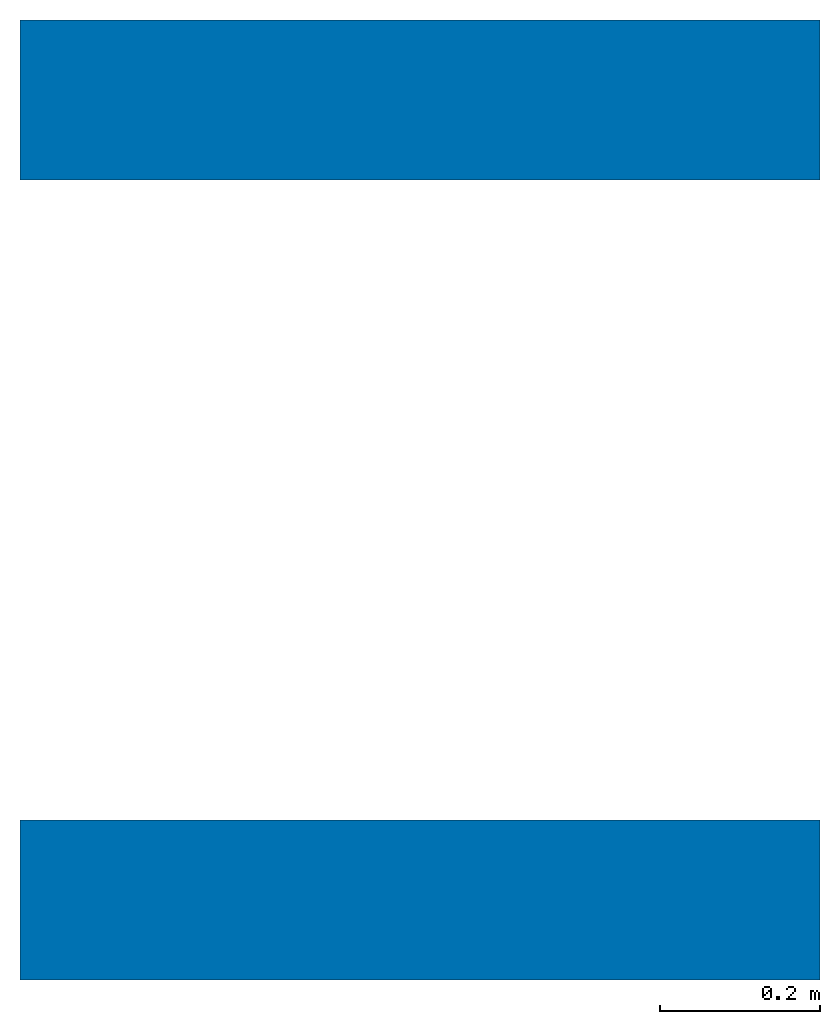
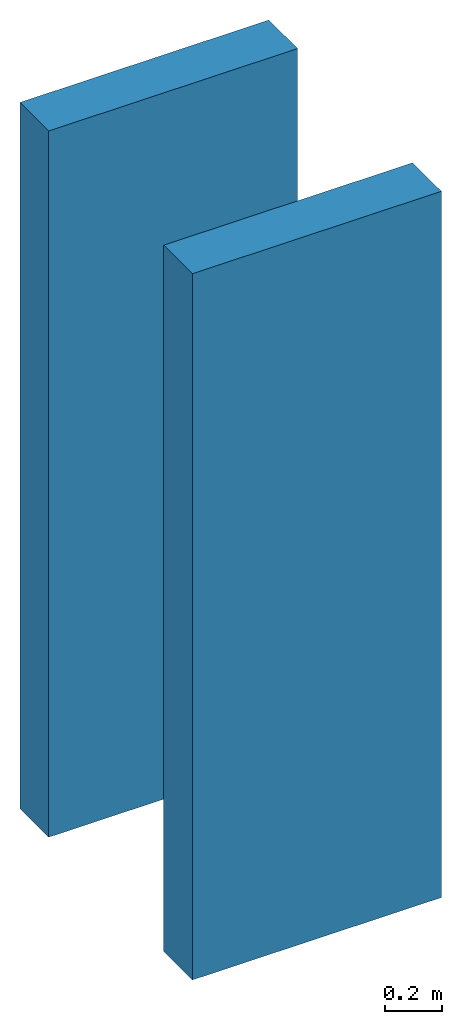
# One storey: 2 walls.
"""IFC4 building model written with IfcOpenShell, lengths in metres."""

from ifc_helpers import new_model, si_unit, frame, origin_with_axes, place, context, subcontext, project, spatial, polygons, source, transform, mapped, element, save


model = new_model("IFC4")

# Units and contexts
model_context = context("Model", 3, precision=1e-05, world=origin_with_axes())
plan_context = context("Plan", 2, precision=1e-05, world=origin_with_axes())
body_context = subcontext(model_context, "Body", "Model", "MODEL_VIEW")
ifc_project = project(units=[si_unit("LENGTHUNIT", "METRE"), si_unit("AREAUNIT", "SQUARE_METRE"), si_unit("VOLUMEUNIT", "CUBIC_METRE")], contexts=[model_context, plan_context])

# Site, building, storey
site_placement = place(None, origin_with_axes())
site = spatial("IfcSite", under=ifc_project, at=site_placement)
building_placement = place(site_placement, origin_with_axes())
building = spatial("IfcBuilding", under=site, at=building_placement, Name="Building")
storey_placement = place(building_placement, origin_with_axes())
storey = spatial("IfcBuildingStorey", under=building, at=storey_placement, Name="Ground Floor")

# Walls
shared_shape_1 = source(origin_with_axes(), body_context, "Body", "Tessellation", [
    polygons([(0.0, 0.0, 0.0), (1.0, 0.0, 0.0), (0.0, 0.0, 3.0), (1.0, 0.0, 3.0), (0.0, -0.200000002980232, 0.0), (1.0, -0.200000002980232, 0.0), (0.0, -0.200000002980232, 3.0), (1.0, -0.200000002980232, 3.0)], [[[3, 4, 2, 1]], [[7, 5, 6, 8]], [[1, 2, 6, 5]], [[3, 1, 5, 7]], [[2, 4, 8, 6]], [[4, 3, 7, 8]]]),
])
wall_1_placement = place(storey_placement, origin_with_axes())
element("IfcWall", 1, at=wall_1_placement, inside=storey, Name="Wall", PredefinedType="STANDARD", context=body_context, shape_type="MappedRepresentation", body=[
    mapped(shared_shape_1, transform((0.0, 0.0, 0.0), x_axis=(1.0, 0.0, 0.0), y_axis=(0.0, 1.0, 0.0), z_axis=(0.0, 0.0, 1.0), scale=1.0)),
])
shared_shape_2 = source(origin_with_axes(), body_context, "Body", "Tessellation", [
    polygons([(0.0, 0.0, 0.0), (1.0, 0.0, 0.0), (0.0, 0.0, 3.0), (1.0, 0.0, 3.0), (0.0, -0.200000002980232, 0.0), (1.0, -0.200000002980232, 0.0), (0.0, -0.200000002980232, 3.0), (1.0, -0.200000002980232, 3.0)], [[[3, 4, 2, 1]], [[7, 5, 6, 8]], [[1, 2, 6, 5]], [[3, 1, 5, 7]], [[2, 4, 8, 6]], [[4, 3, 7, 8]]]),
])
wall_2_placement = place(storey_placement, frame((0.0, 1.0, 0.0), z_axis=(0.0, 0.0, 1.0), x_axis=(1.0, 0.0, 0.0)))
element("IfcWall", 2, at=wall_2_placement, inside=storey, Name="Wall.001", PredefinedType="STANDARD", context=body_context, shape_type="MappedRepresentation", body=[
    mapped(shared_shape_2, transform((0.0, 0.0, 0.0), x_axis=(1.0, 0.0, 0.0), y_axis=(0.0, 1.0, 0.0), z_axis=(0.0, 0.0, 1.0), scale=1.0)),
])

save(model, "model.ifc")
